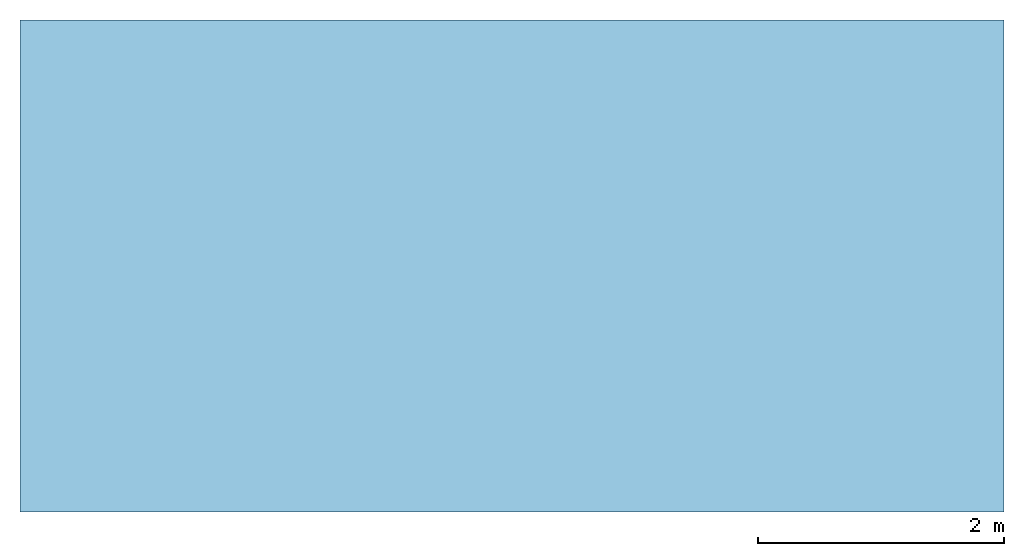
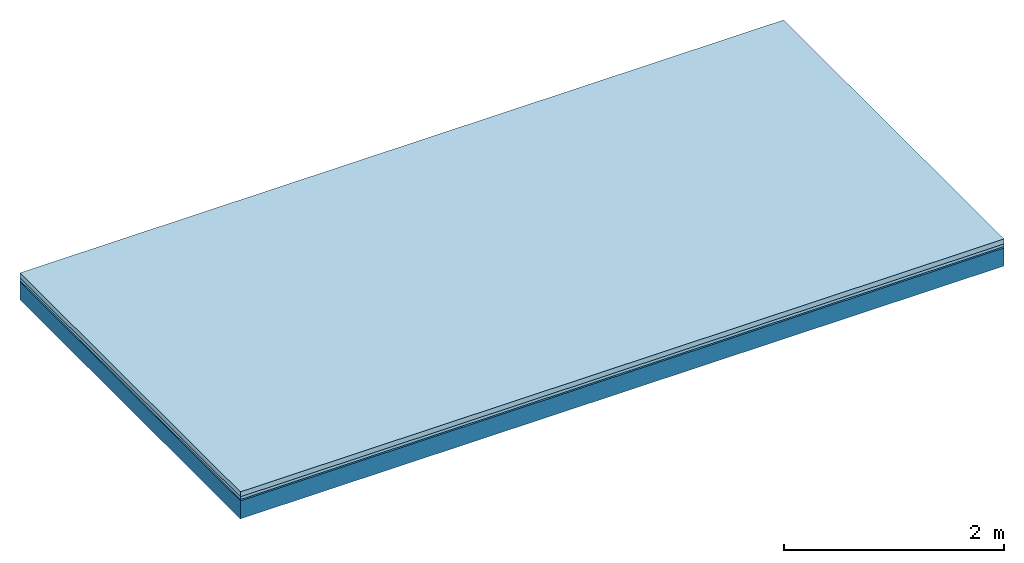
# One storey: 3 plates, 1 member, 1 element without a shape of its own.
"""IFC4 building model written with IfcOpenShell, lengths in metres."""

from ifc_helpers import new_model, si_unit, derived_unit, direction, frame, frame_2d, origin, origin_with_axes, place, context, project, spatial, rectangle, extrude, material, layer, layer_set, type_object, element, aggregate, save


model = new_model("IFC4")

# Units and contexts
plan_context = context("Plan", 3, precision=1e-05, world=origin(), true_north=direction((0.0, 1.0)))
model_context = context("Model", 3, precision=1e-05, world=origin(), true_north=direction((0.0, 1.0)))
ifc_project = project(units=[si_unit("LENGTHUNIT", "METRE"), derived_unit("SOUNDPRESSUREUNIT", [(si_unit("PRESSUREUNIT", "PASCAL", prefix="MICRO"), 0)]), si_unit("ENERGYUNIT", "JOULE", prefix="MEGA"), si_unit("MASSUNIT", "GRAM", prefix="KILO"), derived_unit("THERMALTRANSMITTANCEUNIT", [(si_unit("POWERUNIT", "WATT"), 1), (si_unit("AREAUNIT", "SQUARE_METRE"), -1), (si_unit("THERMODYNAMICTEMPERATUREUNIT", "KELVIN"), -1)]), derived_unit("AREADENSITYUNIT", [(si_unit("MASSUNIT", "GRAM", prefix="KILO"), 1), (si_unit("AREAUNIT", "SQUARE_METRE"), -1)]), derived_unit("USERDEFINED", [(si_unit("ENERGYUNIT", "JOULE", prefix="MEGA"), 1), (si_unit("AREAUNIT", "SQUARE_METRE"), -1)])], contexts=[plan_context, model_context])

# Site, building, storey
site = spatial("IfcSite", under=ifc_project)
building_placement = place(None, origin())
building = spatial("IfcBuilding", under=site, at=building_placement)
storey_placement = place(building_placement, origin())
storey = spatial("IfcBuildingStorey", under=building, at=storey_placement)

# Slab, member, plates
ifc_material_1 = material(Category="04.005")
ifc_layer_1 = layer(ifc_material_1, 0.055, Name="On-material")
ifc_material_2 = material()
ifc_layer_2 = layer(ifc_material_2, 0.03, Name="Impact sound insulation")
ifc_material_3 = material(Category="03.007")
ifc_layer_3 = layer(ifc_material_3, 0.015, Name="on Supporting structure")
ifc_material_4 = material(Name="of the art")
ifc_layer_4 = layer(ifc_material_4, 0.0, Name="Bond")
ifc_layer_5 = layer(None, 0.2, Name="Supporting structure")
ifc_layer_set = layer_set([ifc_layer_1, ifc_layer_2, ifc_layer_3, ifc_layer_4, ifc_layer_5])
slab_type = type_object("IfcSlabType", Name="A0844", PredefinedType="NOTDEFINED", material=ifc_layer_set)
slab_placement = place(None, frame((0.0, 0.0, 0.0), z_axis=(0.0, 0.0, -1.0), x_axis=(1.0, 0.0, 0.0)))
slab = element("IfcSlab", 1, at=slab_placement, inside=storey, type_object=slab_type, material=ifc_layer_set, Name="Slab #1")
ifc_material_5 = material()
member_placement = place(slab_placement, origin())
member = element("IfcMember", 2, at=member_placement, material=ifc_material_5, Name="Supporting structure", context=plan_context, shape_type="SweptSolid", body=[
    extrude(rectangle(XDim=1.0, YDim=0.2, at=frame_2d((0.5, 0.1), x_axis=(1.0, 0.0))), frame((0.0, 4.0, 0.1), z_axis=(0.0, -1.0, 0.0), x_axis=(1.0, 0.0, 0.0)), (0.0, 0.0, 1.0), 4.0),
    extrude(rectangle(XDim=1.0, YDim=0.2, at=frame_2d((0.5, 0.1), x_axis=(1.0, 0.0))), frame((1.0, 4.0, 0.1), z_axis=(0.0, -1.0, 0.0), x_axis=(1.0, 0.0, 0.0)), (0.0, 0.0, 1.0), 4.0),
    extrude(rectangle(XDim=1.0, YDim=0.2, at=frame_2d((0.5, 0.1), x_axis=(1.0, 0.0))), frame((2.0, 4.0, 0.1), z_axis=(0.0, -1.0, 0.0), x_axis=(1.0, 0.0, 0.0)), (0.0, 0.0, 1.0), 4.0),
    extrude(rectangle(XDim=1.0, YDim=0.2, at=frame_2d((0.5, 0.1), x_axis=(1.0, 0.0))), frame((3.0, 4.0, 0.1), z_axis=(0.0, -1.0, 0.0), x_axis=(1.0, 0.0, 0.0)), (0.0, 0.0, 1.0), 4.0),
    extrude(rectangle(XDim=1.0, YDim=0.2, at=frame_2d((0.5, 0.1), x_axis=(1.0, 0.0))), frame((4.0, 4.0, 0.1), z_axis=(0.0, -1.0, 0.0), x_axis=(1.0, 0.0, 0.0)), (0.0, 0.0, 1.0), 4.0),
    extrude(rectangle(XDim=1.0, YDim=0.2, at=frame_2d((0.5, 0.1), x_axis=(1.0, 0.0))), frame((5.0, 4.0, 0.1), z_axis=(0.0, -1.0, 0.0), x_axis=(1.0, 0.0, 0.0)), (0.0, 0.0, 1.0), 4.0),
    extrude(rectangle(XDim=1.0, YDim=0.2, at=frame_2d((0.5, 0.1), x_axis=(1.0, 0.0))), frame((6.0, 4.0, 0.1), z_axis=(0.0, -1.0, 0.0), x_axis=(1.0, 0.0, 0.0)), (0.0, 0.0, 1.0), 4.0),
    extrude(rectangle(XDim=1.0, YDim=0.2, at=frame_2d((0.5, 0.1), x_axis=(1.0, 0.0))), frame((7.0, 4.0, 0.1), z_axis=(0.0, -1.0, 0.0), x_axis=(1.0, 0.0, 0.0)), (0.0, 0.0, 1.0), 4.0),
])
plate_1_placement = place(slab_placement, origin())
plate_1 = element("IfcPlate", 3, at=plate_1_placement, material=ifc_material_1, Name="On-material", context=plan_context, shape_type="SweptSolid", body=[
    extrude(rectangle(XDim=8.0, YDim=4.0, at=frame_2d((4.0, 2.0), x_axis=(1.0, 0.0))), origin_with_axes(), (0.0, 0.0, 1.0), 0.055),
])
plate_2_placement = place(slab_placement, origin())
plate_2 = element("IfcPlate", 4, at=plate_2_placement, material=ifc_material_2, Name="Impact sound insulation", context=plan_context, shape_type="SweptSolid", body=[
    extrude(rectangle(XDim=8.0, YDim=4.0, at=frame_2d((4.0, 2.0), x_axis=(1.0, 0.0))), frame((0.0, 0.0, 0.055), z_axis=(0.0, 0.0, 1.0), x_axis=(1.0, 0.0, 0.0)), (0.0, 0.0, 1.0), 0.03),
])
plate_3_placement = place(slab_placement, origin())
plate_3 = element("IfcPlate", 5, at=plate_3_placement, material=ifc_material_3, Name="on Supporting structure", context=plan_context, shape_type="SweptSolid", body=[
    extrude(rectangle(XDim=8.0, YDim=4.0, at=frame_2d((4.0, 2.0), x_axis=(1.0, 0.0))), frame((0.0, 0.0, 0.085), z_axis=(0.0, 0.0, 1.0), x_axis=(1.0, 0.0, 0.0)), (0.0, 0.0, 1.0), 0.015),
])
aggregate(slab, [plate_1, plate_2, plate_3, member])

save(model, "model.ifc")
